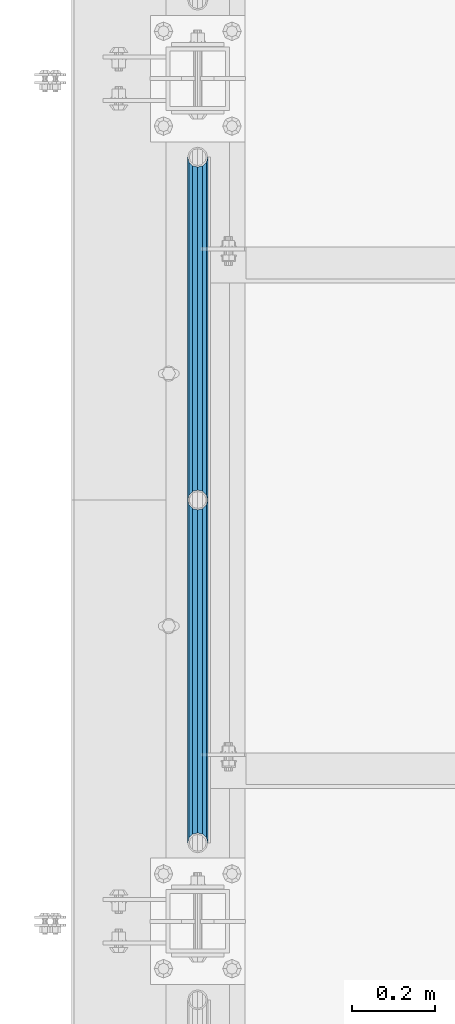
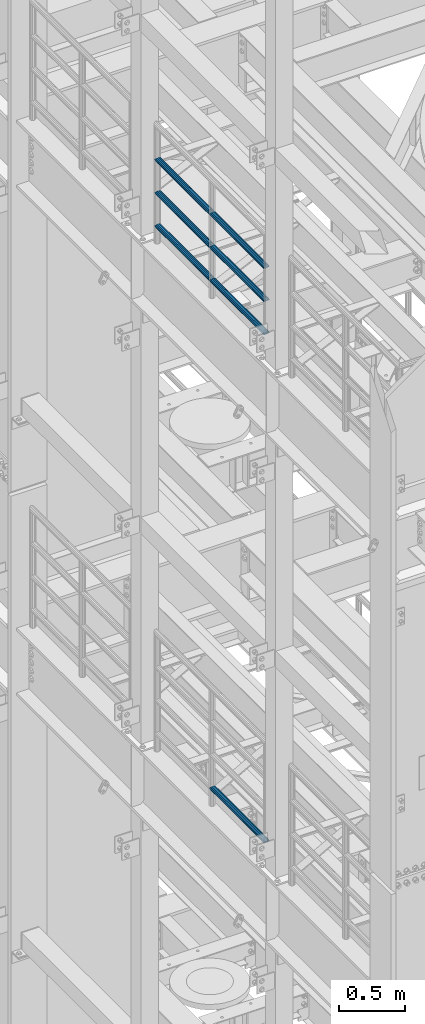
# One storey, part 1226 of 1876: 7 beams, 2 elements without a shape of their own.
"""IFC2X3 building model written with IfcOpenShell, lengths in millimetres."""

from ifc_helpers import new_model, si_unit, frame, origin_with_axes, place, context, subcontext, project, spatial, faceted_brep, material, type_object, element, aggregate, save


model = new_model("IFC2X3")

# Units and contexts
model_context = context("Model", 3, precision=1e-05, world=origin_with_axes())
body_context = subcontext(model_context, "Body", "Model", "MODEL_VIEW")
ifc_project = project(units=[si_unit("LENGTHUNIT", "METRE", prefix="MILLI"), si_unit("AREAUNIT", "SQUARE_METRE"), si_unit("VOLUMEUNIT", "CUBIC_METRE"), si_unit("MASSUNIT", "GRAM", prefix="KILO"), si_unit("TIMEUNIT", "SECOND"), si_unit("PLANEANGLEUNIT", "RADIAN"), si_unit("SOLIDANGLEUNIT", "STERADIAN"), si_unit("THERMODYNAMICTEMPERATUREUNIT", "DEGREE_CELSIUS"), si_unit("LUMINOUSINTENSITYUNIT", "LUMEN")], contexts=[model_context])

# Site, building, storey
site_placement = place(None, origin_with_axes())
site = spatial("IfcSite", under=ifc_project, at=site_placement, CompositionType="ELEMENT")
building_placement = place(site_placement, origin_with_axes())
building = spatial("IfcBuilding", under=site, at=building_placement, Name="Undefined", CompositionType="ELEMENT")
storey_placement = place(building_placement, origin_with_axes())
storey = spatial("IfcBuildingStorey", under=building, at=storey_placement, Name="Undefined", CompositionType="ELEMENT", Elevation=0.0)

# Assembly, beams
assembly_1_placement = place(storey_placement, origin_with_axes())
assembly_1 = element("IfcElementAssembly", 1, at=assembly_1_placement, inside=storey, Name="RAIL", AssemblyPlace="NOTDEFINED", PredefinedType="RIGID_FRAME")
ifc_material = material()
beam_type = type_object("IfcBeamType", Name="PIPE1-1/2SCH40", PredefinedType="NOTDEFINED")
beam_1_placement = place(assembly_1_placement, frame((-1.81898940354586e-12, -1524.0, 18145.125), z_axis=(0.0, 0.0, 1.0), x_axis=(0.0, -1.0, 0.0)))
beam_1 = element("IfcBeam", 2, at=beam_1_placement, type_object=beam_type, material=ifc_material, Name="RAIL", ObjectType="PIPE1-1/2SCH40", context=body_context, shape_type="Brep", body=[
    faceted_brep([(805.872807006681, -12.0649999999996, 20.8971929933177), (805.872807006683, -12.0649999999996, 15.8661214311796), (805.379378568819, -10.2235000000001, 17.7076214311819), (802.640000000001, 0.0, 20.4470000000001), (802.640000000001, 0.0, 24.130000000001), (805.379378568819, 10.2235000000001, 17.7076214311819), (805.872807006683, 12.0649999999996, 15.8661214311796), (805.872807006681, 12.0649999999996, 20.8971929933177), (826.77, 24.1300000000001, 0.0), (814.705, 20.8971929933186, 12.0649999999987), (814.705, 20.8971929933186, -12.0649999999987), (811.515428437862, 17.7076214311801, 10.2235000000001), (814.254807006682, 20.4470000000001, 0.0), (811.515428437862, 17.7076214311801, -10.2235000000001), (805.872807006683, 12.0649999999996, -15.8661214311796), (805.872807006681, 12.0649999999996, -20.8971929933177), (805.379378568819, 10.2235000000001, -17.7076214311819), (802.640000000001, 0.0, -20.4470000000001), (802.640000000001, 0.0, -24.130000000001), (805.872807006683, -12.0649999999996, -15.8661214311796), (805.872807006681, -12.0649999999996, -20.8971929933177), (805.379378568819, -10.2235000000001, -17.7076214311819), (826.77, -24.1300000000001, 0.0), (814.705, -20.8971929933186, -12.0649999999987), (814.705, -20.8971929933186, 12.0649999999987), (811.515428437862, -17.7076214311801, -10.2235000000001), (814.254807006682, -20.4470000000001, 0.0), (811.515428437862, -17.7076214311801, 10.2235000000001), (12.0650000000064, -20.8971929933177, -12.0649999999987), (20.8971929933249, -12.0650000000005, -20.8971929933177), (0.0, 24.1299999999992, 0.0), (12.0650000000064, 20.8971929933177, -12.0649999999987), (12.0650000000064, 20.8971929933177, 12.0649999999987), (20.8971929933249, 12.0650000000005, 20.8971929933177), (24.1300000000064, 0.0, 24.130000000001), (20.8971929933249, 12.0650000000005, -20.8971929933177), (24.1300000000063, 0.0, -24.130000000001), (24.1300000000063, 0.0, -20.4470000000001), (20.8971929933249, -12.0650000000005, -15.8661214311796), (21.3906214311868, -10.2235000000001, -17.7076214311819), (21.3906214311868, 10.2235000000001, -17.7076214311819), (20.8971929933249, 12.0650000000005, -15.8661214311796), (15.2545715621445, 17.7076214311801, -10.2235000000001), (12.5151929933249, 20.4470000000001, 0.0), (15.2545715621445, 17.7076214311801, 10.2235000000001), (20.8971929933249, 12.0650000000005, 15.8661214311796), (21.3906214311868, 10.2235000000001, 17.7076214311819), (24.1300000000064, 0.0, 20.4470000000001), (21.3906214311868, -10.2235000000001, 17.7076214311819), (20.8971929933249, -12.0650000000005, 15.8661214311796), (20.8971929933249, -12.0650000000005, 20.8971929933177), (12.0650000000064, -20.8971929933177, 12.0649999999987), (0.0, -24.1299999999992, 0.0), (15.2545715621445, -17.7076214311801, 10.2235000000001), (12.5151929933249, -20.4470000000001, 0.0), (15.2545715621445, -17.7076214311801, -10.2235000000001)], [[[0, 1, 2, 3, 4]], [[4, 3, 5, 6, 7]], [[8, 9, 10]], [[7, 6, 11, 12, 13, 14, 15, 10, 9]], [[16, 17, 18, 15, 14]], [[19, 20, 18, 17, 21]], [[22, 23, 24]], [[24, 23, 20, 19, 25, 26, 27, 1, 0]], [[28, 29, 20, 23]], [[30, 31, 32]], [[33, 34, 4, 7]], [[32, 33, 7, 9]], [[30, 32, 9, 8]], [[31, 30, 8, 10]], [[35, 31, 10, 15]], [[36, 35, 15, 18]], [[29, 36, 18, 20]], [[37, 36, 29, 38, 39]], [[40, 41, 35, 36, 37]], [[32, 31, 35, 41, 42, 43, 44, 45, 33]], [[33, 45, 46, 47, 34]], [[34, 47, 48, 49, 50]], [[34, 50, 0, 4]], [[50, 51, 24, 0]], [[51, 52, 22, 24]], [[52, 28, 23, 22]], [[51, 28, 52]], [[50, 49, 53, 54, 55, 38, 29, 28, 51]], [[55, 54, 26, 25]], [[21, 39, 38, 55, 25, 19]], [[37, 39, 21, 17]], [[40, 37, 17, 16]], [[42, 41, 40, 16, 14, 13]], [[43, 42, 13, 12]], [[44, 43, 12, 11]], [[5, 46, 45, 44, 11, 6]], [[47, 46, 5, 3]], [[48, 47, 3, 2]], [[53, 49, 48, 2, 1, 27]], [[54, 53, 27, 26]]]),
])
beam_2_placement = place(assembly_1_placement, frame((-1.81898940354586e-12, -697.230000000001, 18145.125), z_axis=(0.0, 0.0, 1.0), x_axis=(0.0, -1.0, 0.0)))
beam_2 = element("IfcBeam", 3, at=beam_2_placement, type_object=beam_type, material=ifc_material, Name="RAIL", ObjectType="PIPE1-1/2SCH40", context=body_context, shape_type="Brep", body=[
    faceted_brep([(805.872807006681, -12.0649999999996, 20.8971929933177), (805.872807006683, -12.0649999999996, 15.8661214311796), (805.379378568819, -10.2235000000001, 17.7076214311819), (802.640000000001, 0.0, 20.4470000000001), (802.640000000001, 0.0, 24.130000000001), (805.379378568819, 10.2235000000001, 17.7076214311819), (805.872807006683, 12.0649999999996, 15.8661214311796), (805.872807006681, 12.0649999999996, 20.8971929933177), (826.77, 24.1300000000001, 0.0), (814.705, 20.8971929933186, 12.0649999999987), (814.705, 20.8971929933186, -12.0649999999987), (811.515428437862, 17.7076214311801, 10.2235000000001), (814.254807006682, 20.4470000000001, 0.0), (811.515428437862, 17.7076214311801, -10.2235000000001), (805.872807006683, 12.0649999999996, -15.8661214311796), (805.872807006681, 12.0649999999996, -20.8971929933177), (805.379378568819, 10.2235000000001, -17.7076214311819), (802.640000000001, 0.0, -20.4470000000001), (802.640000000001, 0.0, -24.130000000001), (805.872807006683, -12.0649999999996, -15.8661214311796), (805.872807006681, -12.0649999999996, -20.8971929933177), (805.379378568819, -10.2235000000001, -17.7076214311819), (826.77, -24.1300000000001, 0.0), (814.705, -20.8971929933186, -12.0649999999987), (814.705, -20.8971929933186, 12.0649999999987), (811.515428437862, -17.7076214311801, -10.2235000000001), (814.254807006682, -20.4470000000001, 0.0), (811.515428437862, -17.7076214311801, 10.2235000000001), (12.0650000000064, -20.8971929933177, -12.0649999999987), (20.8971929933249, -12.0650000000005, -20.8971929933177), (0.0, 24.1299999999992, 0.0), (12.0650000000064, 20.8971929933177, -12.0649999999987), (12.0650000000064, 20.8971929933177, 12.0649999999987), (20.8971929933249, 12.0650000000005, 20.8971929933177), (24.1300000000064, 0.0, 24.130000000001), (20.8971929933249, 12.0650000000005, -20.8971929933177), (24.1300000000063, 0.0, -24.130000000001), (24.1300000000063, 0.0, -20.4470000000001), (20.8971929933249, -12.0650000000005, -15.8661214311796), (21.3906214311868, -10.2235000000001, -17.7076214311819), (21.3906214311868, 10.2235000000001, -17.7076214311819), (20.8971929933249, 12.0650000000005, -15.8661214311796), (15.2545715621445, 17.7076214311801, -10.2235000000001), (12.5151929933249, 20.4470000000001, 0.0), (15.2545715621445, 17.7076214311801, 10.2235000000001), (20.8971929933249, 12.0650000000005, 15.8661214311796), (21.3906214311868, 10.2235000000001, 17.7076214311819), (24.1300000000064, 0.0, 20.4470000000001), (21.3906214311868, -10.2235000000001, 17.7076214311819), (20.8971929933249, -12.0650000000005, 15.8661214311796), (20.8971929933249, -12.0650000000005, 20.8971929933177), (12.0650000000064, -20.8971929933177, 12.0649999999987), (0.0, -24.1299999999992, 0.0), (15.2545715621445, -17.7076214311801, 10.2235000000001), (12.5151929933249, -20.4470000000001, 0.0), (15.2545715621445, -17.7076214311801, -10.2235000000001)], [[[0, 1, 2, 3, 4]], [[4, 3, 5, 6, 7]], [[8, 9, 10]], [[7, 6, 11, 12, 13, 14, 15, 10, 9]], [[16, 17, 18, 15, 14]], [[19, 20, 18, 17, 21]], [[22, 23, 24]], [[24, 23, 20, 19, 25, 26, 27, 1, 0]], [[28, 29, 20, 23]], [[30, 31, 32]], [[33, 34, 4, 7]], [[32, 33, 7, 9]], [[30, 32, 9, 8]], [[31, 30, 8, 10]], [[35, 31, 10, 15]], [[36, 35, 15, 18]], [[29, 36, 18, 20]], [[37, 36, 29, 38, 39]], [[40, 41, 35, 36, 37]], [[32, 31, 35, 41, 42, 43, 44, 45, 33]], [[33, 45, 46, 47, 34]], [[34, 47, 48, 49, 50]], [[34, 50, 0, 4]], [[50, 51, 24, 0]], [[51, 52, 22, 24]], [[52, 28, 23, 22]], [[51, 28, 52]], [[50, 49, 53, 54, 55, 38, 29, 28, 51]], [[55, 54, 26, 25]], [[21, 39, 38, 55, 25, 19]], [[37, 39, 21, 17]], [[40, 37, 17, 16]], [[42, 41, 40, 16, 14, 13]], [[43, 42, 13, 12]], [[44, 43, 12, 11]], [[5, 46, 45, 44, 11, 6]], [[47, 46, 5, 3]], [[48, 47, 3, 2]], [[53, 49, 48, 2, 1, 27]], [[54, 53, 27, 26]]]),
])
beam_3_placement = place(assembly_1_placement, frame((-1.81898940354586e-12, -2350.77, 18449.925), z_axis=(0.0, 0.0, -1.0), x_axis=(0.0, 1.0, 0.0)))
beam_3 = element("IfcBeam", 4, at=beam_3_placement, type_object=beam_type, material=ifc_material, Name="RAIL", ObjectType="PIPE1-1/2SCH40", context=body_context, shape_type="Brep", body=[
    faceted_brep([(0.0, 24.1299999999992, 0.0), (12.0650000000064, 20.8971929933177, -12.0649999999987), (12.0650000000064, 20.8971929933177, 12.0649999999987), (12.0650000000064, -20.8971929933177, 12.0649999999987), (12.0650000000064, -20.8971929933177, -12.0649999999987), (0.0, -24.1299999999992, 0.0), (20.8971929933249, -12.0650000000005, 20.8971929933177), (20.8971929933249, -12.0650000000005, 15.8661214311796), (15.2545715621445, -17.7076214311801, 10.2235000000001), (12.5151929933249, -20.4470000000001, 0.0), (15.2545715621445, -17.7076214311801, -10.2235000000001), (20.8971929933249, -12.0650000000005, -15.8661214311796), (20.8971929933249, -12.0650000000005, -20.8971929933177), (24.1300000000063, 0.0, -20.4470000000001), (24.1300000000063, 0.0, -24.130000000001), (21.3906214311868, -10.2235000000001, -17.7076214311819), (21.3906214311868, 10.2235000000001, -17.7076214311819), (20.8971929933249, 12.0650000000005, -15.8661214311796), (20.8971929933249, 12.0650000000005, -20.8971929933177), (15.2545715621445, 17.7076214311801, -10.2235000000001), (12.5151929933249, 20.4470000000001, 0.0), (15.2545715621445, 17.7076214311801, 10.2235000000001), (20.8971929933249, 12.0650000000005, 15.8661214311796), (20.8971929933249, 12.0650000000005, 20.8971929933177), (21.3906214311868, 10.2235000000001, 17.7076214311819), (24.1300000000064, 0.0, 20.4470000000001), (24.1300000000064, 0.0, 24.130000000001), (21.3906214311868, -10.2235000000001, 17.7076214311819), (826.77, 24.1300000000001, 0.0), (814.705, 20.8971929933186, -12.0649999999987), (805.872807006681, 12.0649999999996, -20.8971929933177), (826.77, -24.1300000000001, 0.0), (814.705, -20.8971929933186, -12.0649999999987), (814.705, -20.8971929933186, 12.0649999999987), (805.872807006681, -12.0649999999996, 20.8971929933177), (805.872807006681, -12.0649999999996, -20.8971929933177), (802.640000000001, 0.0, -24.130000000001), (805.379378568819, 10.2235000000001, -17.7076214311819), (802.640000000001, 0.0, -20.4470000000001), (805.872807006683, 12.0649999999996, -15.8661214311796), (805.872807006683, -12.0649999999996, -15.8661214311796), (805.379378568819, -10.2235000000001, -17.7076214311819), (811.515428437862, -17.7076214311801, -10.2235000000001), (814.254807006682, -20.4470000000001, 0.0), (811.515428437862, -17.7076214311801, 10.2235000000001), (805.872807006683, -12.0649999999996, 15.8661214311796), (805.379378568819, -10.2235000000001, 17.7076214311819), (802.640000000001, 0.0, 20.4470000000001), (802.640000000001, 0.0, 24.130000000001), (805.872807006681, 12.0649999999996, 20.8971929933177), (814.705, 20.8971929933186, 12.0649999999987), (805.872807006683, 12.0649999999996, 15.8661214311796), (811.515428437862, 17.7076214311801, 10.2235000000001), (814.254807006682, 20.4470000000001, 0.0), (811.515428437862, 17.7076214311801, -10.2235000000001), (805.379378568819, 10.2235000000001, 17.7076214311819)], [[[0, 1, 2]], [[3, 4, 5]], [[6, 7, 8, 9, 10, 11, 12, 4, 3]], [[13, 14, 12, 11, 15]], [[16, 17, 18, 14, 13]], [[2, 1, 18, 17, 19, 20, 21, 22, 23]], [[23, 22, 24, 25, 26]], [[26, 25, 27, 7, 6]], [[1, 0, 28, 29]], [[18, 1, 29, 30]], [[31, 32, 33]], [[6, 3, 33, 34]], [[3, 5, 31, 33]], [[5, 4, 32, 31]], [[4, 12, 35, 32]], [[12, 14, 36, 35]], [[14, 18, 30, 36]], [[37, 38, 36, 30, 39]], [[40, 35, 36, 38, 41]], [[33, 32, 35, 40, 42, 43, 44, 45, 34]], [[34, 45, 46, 47, 48]], [[26, 6, 34, 48]], [[2, 23, 49, 50]], [[23, 26, 48, 49]], [[0, 2, 50, 28]], [[28, 50, 29]], [[49, 51, 52, 53, 54, 39, 30, 29, 50]], [[48, 47, 55, 51, 49]], [[25, 24, 55, 47]], [[55, 24, 22, 21, 52, 51]], [[21, 20, 53, 52]], [[20, 19, 54, 53]], [[19, 17, 16, 37, 39, 54]], [[16, 13, 38, 37]], [[13, 15, 41, 38]], [[41, 15, 11, 10, 42, 40]], [[10, 9, 43, 42]], [[9, 8, 44, 43]], [[8, 7, 27, 46, 45, 44]], [[27, 25, 47, 46]]]),
])
beam_4_placement = place(assembly_1_placement, frame((-1.81898940354586e-12, -1524.0, 18449.925), z_axis=(0.0, 0.0, -1.0), x_axis=(0.0, 1.0, 0.0)))
beam_4 = element("IfcBeam", 5, at=beam_4_placement, type_object=beam_type, material=ifc_material, Name="RAIL", ObjectType="PIPE1-1/2SCH40", context=body_context, shape_type="Brep", body=[
    faceted_brep([(0.0, 24.1299999999992, 0.0), (12.0650000000064, 20.8971929933177, -12.0649999999987), (12.0650000000064, 20.8971929933177, 12.0649999999987), (12.0650000000064, -20.8971929933177, 12.0649999999987), (12.0650000000064, -20.8971929933177, -12.0649999999987), (0.0, -24.1299999999992, 0.0), (20.8971929933249, -12.0650000000005, 20.8971929933177), (20.8971929933249, -12.0650000000005, 15.8661214311796), (15.2545715621445, -17.7076214311801, 10.2235000000001), (12.5151929933249, -20.4470000000001, 0.0), (15.2545715621445, -17.7076214311801, -10.2235000000001), (20.8971929933249, -12.0650000000005, -15.8661214311796), (20.8971929933249, -12.0650000000005, -20.8971929933177), (24.1300000000063, 0.0, -20.4470000000001), (24.1300000000063, 0.0, -24.130000000001), (21.3906214311868, -10.2235000000001, -17.7076214311819), (21.3906214311868, 10.2235000000001, -17.7076214311819), (20.8971929933249, 12.0650000000005, -15.8661214311796), (20.8971929933249, 12.0650000000005, -20.8971929933177), (15.2545715621445, 17.7076214311801, -10.2235000000001), (12.5151929933249, 20.4470000000001, 0.0), (15.2545715621445, 17.7076214311801, 10.2235000000001), (20.8971929933249, 12.0650000000005, 15.8661214311796), (20.8971929933249, 12.0650000000005, 20.8971929933177), (21.3906214311868, 10.2235000000001, 17.7076214311819), (24.1300000000064, 0.0, 20.4470000000001), (24.1300000000064, 0.0, 24.130000000001), (21.3906214311868, -10.2235000000001, 17.7076214311819), (826.77, 24.1300000000001, 0.0), (814.705, 20.8971929933186, -12.0649999999987), (805.872807006681, 12.0649999999996, -20.8971929933177), (826.77, -24.1300000000001, 0.0), (814.705, -20.8971929933186, -12.0649999999987), (814.705, -20.8971929933186, 12.0649999999987), (805.872807006681, -12.0649999999996, 20.8971929933177), (805.872807006681, -12.0649999999996, -20.8971929933177), (802.640000000001, 0.0, -24.130000000001), (805.379378568819, 10.2235000000001, -17.7076214311819), (802.640000000001, 0.0, -20.4470000000001), (805.872807006683, 12.0649999999996, -15.8661214311796), (805.872807006683, -12.0649999999996, -15.8661214311796), (805.379378568819, -10.2235000000001, -17.7076214311819), (811.515428437862, -17.7076214311801, -10.2235000000001), (814.254807006682, -20.4470000000001, 0.0), (811.515428437862, -17.7076214311801, 10.2235000000001), (805.872807006683, -12.0649999999996, 15.8661214311796), (805.379378568819, -10.2235000000001, 17.7076214311819), (802.640000000001, 0.0, 20.4470000000001), (802.640000000001, 0.0, 24.130000000001), (805.872807006681, 12.0649999999996, 20.8971929933177), (814.705, 20.8971929933186, 12.0649999999987), (805.872807006683, 12.0649999999996, 15.8661214311796), (811.515428437862, 17.7076214311801, 10.2235000000001), (814.254807006682, 20.4470000000001, 0.0), (811.515428437862, 17.7076214311801, -10.2235000000001), (805.379378568819, 10.2235000000001, 17.7076214311819)], [[[0, 1, 2]], [[3, 4, 5]], [[6, 7, 8, 9, 10, 11, 12, 4, 3]], [[13, 14, 12, 11, 15]], [[16, 17, 18, 14, 13]], [[2, 1, 18, 17, 19, 20, 21, 22, 23]], [[23, 22, 24, 25, 26]], [[26, 25, 27, 7, 6]], [[1, 0, 28, 29]], [[18, 1, 29, 30]], [[31, 32, 33]], [[6, 3, 33, 34]], [[3, 5, 31, 33]], [[5, 4, 32, 31]], [[4, 12, 35, 32]], [[12, 14, 36, 35]], [[14, 18, 30, 36]], [[37, 38, 36, 30, 39]], [[40, 35, 36, 38, 41]], [[33, 32, 35, 40, 42, 43, 44, 45, 34]], [[34, 45, 46, 47, 48]], [[26, 6, 34, 48]], [[2, 23, 49, 50]], [[23, 26, 48, 49]], [[0, 2, 50, 28]], [[28, 50, 29]], [[49, 51, 52, 53, 54, 39, 30, 29, 50]], [[48, 47, 55, 51, 49]], [[25, 24, 55, 47]], [[55, 24, 22, 21, 52, 51]], [[21, 20, 53, 52]], [[20, 19, 54, 53]], [[19, 17, 16, 37, 39, 54]], [[16, 13, 38, 37]], [[13, 15, 41, 38]], [[41, 15, 11, 10, 42, 40]], [[10, 9, 43, 42]], [[9, 8, 44, 43]], [[8, 7, 27, 46, 45, 44]], [[27, 25, 47, 46]]]),
])
beam_5_placement = place(assembly_1_placement, frame((-1.81898940354586e-12, -2350.77, 18754.725), z_axis=(0.0, 0.0, -1.0), x_axis=(0.0, 1.0, 0.0)))
beam_5 = element("IfcBeam", 6, at=beam_5_placement, type_object=beam_type, material=ifc_material, Name="RAIL", ObjectType="PIPE1-1/2SCH40", context=body_context, shape_type="Brep", body=[
    faceted_brep([(0.0, 24.1299999999992, 0.0), (12.0650000000064, 20.8971929933177, -12.0649999999987), (12.0650000000064, 20.8971929933177, 12.0649999999987), (12.0650000000064, -20.8971929933177, 12.0649999999987), (12.0650000000064, -20.8971929933177, -12.0649999999987), (0.0, -24.1299999999992, 0.0), (20.8971929933249, -12.0650000000005, 20.8971929933177), (20.8971929933249, -12.0650000000005, 15.8661214311796), (15.2545715621445, -17.7076214311801, 10.2235000000001), (12.5151929933249, -20.4470000000001, 0.0), (15.2545715621445, -17.7076214311801, -10.2235000000001), (20.8971929933249, -12.0650000000005, -15.8661214311796), (20.8971929933249, -12.0650000000005, -20.8971929933177), (24.1300000000063, 0.0, -20.4470000000001), (24.1300000000063, 0.0, -24.130000000001), (21.3906214311868, -10.2235000000001, -17.7076214311819), (21.3906214311868, 10.2235000000001, -17.7076214311819), (20.8971929933249, 12.0650000000005, -15.8661214311796), (20.8971929933249, 12.0650000000005, -20.8971929933177), (15.2545715621445, 17.7076214311801, -10.2235000000001), (12.5151929933249, 20.4470000000001, 0.0), (15.2545715621445, 17.7076214311801, 10.2235000000001), (20.8971929933249, 12.0650000000005, 15.8661214311796), (20.8971929933249, 12.0650000000005, 20.8971929933177), (21.3906214311868, 10.2235000000001, 17.7076214311819), (24.1300000000064, 0.0, 20.4470000000001), (24.1300000000064, 0.0, 24.130000000001), (21.3906214311868, -10.2235000000001, 17.7076214311819), (826.77, 24.1300000000001, 0.0), (814.705, 20.8971929933186, -12.0649999999987), (805.872807006681, 12.0649999999996, -20.8971929933177), (826.77, -24.1300000000001, 0.0), (814.705, -20.8971929933186, -12.0649999999987), (814.705, -20.8971929933186, 12.0649999999987), (805.872807006681, -12.0649999999996, 20.8971929933177), (805.872807006681, -12.0649999999996, -20.8971929933177), (802.640000000001, 0.0, -24.130000000001), (805.379378568819, 10.2235000000001, -17.7076214311819), (802.640000000001, 0.0, -20.4470000000001), (805.872807006683, 12.0649999999996, -15.8661214311796), (805.872807006683, -12.0649999999996, -15.8661214311796), (805.379378568819, -10.2235000000001, -17.7076214311819), (811.515428437862, -17.7076214311801, -10.2235000000001), (814.254807006682, -20.4470000000001, 0.0), (811.515428437862, -17.7076214311801, 10.2235000000001), (805.872807006683, -12.0649999999996, 15.8661214311796), (805.379378568819, -10.2235000000001, 17.7076214311819), (802.640000000001, 0.0, 20.4470000000001), (802.640000000001, 0.0, 24.130000000001), (805.872807006681, 12.0649999999996, 20.8971929933177), (814.705, 20.8971929933186, 12.0649999999987), (805.872807006683, 12.0649999999996, 15.8661214311796), (811.515428437862, 17.7076214311801, 10.2235000000001), (814.254807006682, 20.4470000000001, 0.0), (811.515428437862, 17.7076214311801, -10.2235000000001), (805.379378568819, 10.2235000000001, 17.7076214311819)], [[[0, 1, 2]], [[3, 4, 5]], [[6, 7, 8, 9, 10, 11, 12, 4, 3]], [[13, 14, 12, 11, 15]], [[16, 17, 18, 14, 13]], [[2, 1, 18, 17, 19, 20, 21, 22, 23]], [[23, 22, 24, 25, 26]], [[26, 25, 27, 7, 6]], [[1, 0, 28, 29]], [[18, 1, 29, 30]], [[31, 32, 33]], [[6, 3, 33, 34]], [[3, 5, 31, 33]], [[5, 4, 32, 31]], [[4, 12, 35, 32]], [[12, 14, 36, 35]], [[14, 18, 30, 36]], [[37, 38, 36, 30, 39]], [[40, 35, 36, 38, 41]], [[33, 32, 35, 40, 42, 43, 44, 45, 34]], [[34, 45, 46, 47, 48]], [[26, 6, 34, 48]], [[2, 23, 49, 50]], [[23, 26, 48, 49]], [[0, 2, 50, 28]], [[28, 50, 29]], [[49, 51, 52, 53, 54, 39, 30, 29, 50]], [[48, 47, 55, 51, 49]], [[25, 24, 55, 47]], [[55, 24, 22, 21, 52, 51]], [[21, 20, 53, 52]], [[20, 19, 54, 53]], [[19, 17, 16, 37, 39, 54]], [[16, 13, 38, 37]], [[13, 15, 41, 38]], [[41, 15, 11, 10, 42, 40]], [[10, 9, 43, 42]], [[9, 8, 44, 43]], [[8, 7, 27, 46, 45, 44]], [[27, 25, 47, 46]]]),
])
beam_6_placement = place(assembly_1_placement, frame((-1.81898940354586e-12, -1524.0, 18754.725), z_axis=(0.0, 0.0, -1.0), x_axis=(0.0, 1.0, 0.0)))
beam_6 = element("IfcBeam", 7, at=beam_6_placement, type_object=beam_type, material=ifc_material, Name="RAIL", ObjectType="PIPE1-1/2SCH40", context=body_context, shape_type="Brep", body=[
    faceted_brep([(0.0, 24.1299999999992, 0.0), (12.0650000000064, 20.8971929933177, -12.0649999999987), (12.0650000000064, 20.8971929933177, 12.0649999999987), (12.0650000000064, -20.8971929933177, 12.0649999999987), (12.0650000000064, -20.8971929933177, -12.0649999999987), (0.0, -24.1299999999992, 0.0), (20.8971929933249, -12.0650000000005, 20.8971929933177), (20.8971929933249, -12.0650000000005, 15.8661214311796), (15.2545715621445, -17.7076214311801, 10.2235000000001), (12.5151929933249, -20.4470000000001, 0.0), (15.2545715621445, -17.7076214311801, -10.2235000000001), (20.8971929933249, -12.0650000000005, -15.8661214311796), (20.8971929933249, -12.0650000000005, -20.8971929933177), (24.1300000000063, 0.0, -20.4470000000001), (24.1300000000063, 0.0, -24.130000000001), (21.3906214311868, -10.2235000000001, -17.7076214311819), (21.3906214311868, 10.2235000000001, -17.7076214311819), (20.8971929933249, 12.0650000000005, -15.8661214311796), (20.8971929933249, 12.0650000000005, -20.8971929933177), (15.2545715621445, 17.7076214311801, -10.2235000000001), (12.5151929933249, 20.4470000000001, 0.0), (15.2545715621445, 17.7076214311801, 10.2235000000001), (20.8971929933249, 12.0650000000005, 15.8661214311796), (20.8971929933249, 12.0650000000005, 20.8971929933177), (21.3906214311868, 10.2235000000001, 17.7076214311819), (24.1300000000064, 0.0, 20.4470000000001), (24.1300000000064, 0.0, 24.130000000001), (21.3906214311868, -10.2235000000001, 17.7076214311819), (826.77, 24.1300000000001, 0.0), (814.705, 20.8971929933186, -12.0649999999987), (805.872807006681, 12.0649999999996, -20.8971929933177), (826.77, -24.1300000000001, 0.0), (814.705, -20.8971929933186, -12.0649999999987), (814.705, -20.8971929933186, 12.0649999999987), (805.872807006681, -12.0649999999996, 20.8971929933177), (805.872807006681, -12.0649999999996, -20.8971929933177), (802.640000000001, 0.0, -24.130000000001), (805.379378568819, 10.2235000000001, -17.7076214311819), (802.640000000001, 0.0, -20.4470000000001), (805.872807006683, 12.0649999999996, -15.8661214311796), (805.872807006683, -12.0649999999996, -15.8661214311796), (805.379378568819, -10.2235000000001, -17.7076214311819), (811.515428437862, -17.7076214311801, -10.2235000000001), (814.254807006682, -20.4470000000001, 0.0), (811.515428437862, -17.7076214311801, 10.2235000000001), (805.872807006683, -12.0649999999996, 15.8661214311796), (805.379378568819, -10.2235000000001, 17.7076214311819), (802.640000000001, 0.0, 20.4470000000001), (802.640000000001, 0.0, 24.130000000001), (805.872807006681, 12.0649999999996, 20.8971929933177), (814.705, 20.8971929933186, 12.0649999999987), (805.872807006683, 12.0649999999996, 15.8661214311796), (811.515428437862, 17.7076214311801, 10.2235000000001), (814.254807006682, 20.4470000000001, 0.0), (811.515428437862, 17.7076214311801, -10.2235000000001), (805.379378568819, 10.2235000000001, 17.7076214311819)], [[[0, 1, 2]], [[3, 4, 5]], [[6, 7, 8, 9, 10, 11, 12, 4, 3]], [[13, 14, 12, 11, 15]], [[16, 17, 18, 14, 13]], [[2, 1, 18, 17, 19, 20, 21, 22, 23]], [[23, 22, 24, 25, 26]], [[26, 25, 27, 7, 6]], [[1, 0, 28, 29]], [[18, 1, 29, 30]], [[31, 32, 33]], [[6, 3, 33, 34]], [[3, 5, 31, 33]], [[5, 4, 32, 31]], [[4, 12, 35, 32]], [[12, 14, 36, 35]], [[14, 18, 30, 36]], [[37, 38, 36, 30, 39]], [[40, 35, 36, 38, 41]], [[33, 32, 35, 40, 42, 43, 44, 45, 34]], [[34, 45, 46, 47, 48]], [[26, 6, 34, 48]], [[2, 23, 49, 50]], [[23, 26, 48, 49]], [[0, 2, 50, 28]], [[28, 50, 29]], [[49, 51, 52, 53, 54, 39, 30, 29, 50]], [[48, 47, 55, 51, 49]], [[25, 24, 55, 47]], [[55, 24, 22, 21, 52, 51]], [[21, 20, 53, 52]], [[20, 19, 54, 53]], [[19, 17, 16, 37, 39, 54]], [[16, 13, 38, 37]], [[13, 15, 41, 38]], [[41, 15, 11, 10, 42, 40]], [[10, 9, 43, 42]], [[9, 8, 44, 43]], [[8, 7, 27, 46, 45, 44]], [[27, 25, 47, 46]]]),
])
aggregate(assembly_1, [beam_1, beam_2, beam_3, beam_4, beam_5, beam_6])

# Assembly, beam
assembly_2_placement = place(storey_placement, origin_with_axes())
assembly_2 = element("IfcElementAssembly", 8, at=assembly_2_placement, inside=storey, Name="RAIL", AssemblyPlace="NOTDEFINED", PredefinedType="RIGID_FRAME")
beam_7_placement = place(assembly_2_placement, frame((-1.81898940354586e-12, -1524.0, 13471.525), z_axis=(0.0, 0.0, 1.0), x_axis=(0.0, -1.0, 0.0)))
beam_7 = element("IfcBeam", 9, at=beam_7_placement, type_object=beam_type, material=ifc_material, Name="RAIL", ObjectType="PIPE1-1/2SCH40", context=body_context, shape_type="Brep", body=[
    faceted_brep([(805.872807006681, -12.0649999999996, 20.8971929933177), (805.872807006683, -12.0649999999996, 15.8661214311796), (805.379378568819, -10.2235000000001, 17.7076214311819), (802.640000000001, 0.0, 20.4470000000001), (802.640000000001, 0.0, 24.130000000001), (805.379378568819, 10.2235000000001, 17.7076214311819), (805.872807006683, 12.0649999999996, 15.8661214311796), (805.872807006681, 12.0649999999996, 20.8971929933177), (826.77, 24.1300000000001, 0.0), (814.705, 20.8971929933186, 12.0649999999987), (814.705, 20.8971929933186, -12.0649999999987), (811.515428437862, 17.7076214311801, 10.2235000000001), (814.254807006682, 20.4470000000001, 0.0), (811.515428437862, 17.7076214311801, -10.2235000000001), (805.872807006683, 12.0649999999996, -15.8661214311796), (805.872807006681, 12.0649999999996, -20.8971929933177), (805.379378568819, 10.2235000000001, -17.7076214311819), (802.640000000001, 0.0, -20.4470000000001), (802.640000000001, 0.0, -24.130000000001), (805.872807006683, -12.0649999999996, -15.8661214311796), (805.872807006681, -12.0649999999996, -20.8971929933177), (805.379378568819, -10.2235000000001, -17.7076214311819), (826.77, -24.1300000000001, 0.0), (814.705, -20.8971929933186, -12.0649999999987), (814.705, -20.8971929933186, 12.0649999999987), (811.515428437862, -17.7076214311801, -10.2235000000001), (814.254807006682, -20.4470000000001, 0.0), (811.515428437862, -17.7076214311801, 10.2235000000001), (12.0650000000064, -20.8971929933177, -12.0649999999987), (20.8971929933249, -12.0650000000005, -20.8971929933177), (0.0, 24.1299999999992, 0.0), (12.0650000000064, 20.8971929933177, -12.0649999999987), (12.0650000000064, 20.8971929933177, 12.0649999999987), (20.8971929933249, 12.0650000000005, 20.8971929933177), (24.1300000000064, 0.0, 24.130000000001), (20.8971929933249, 12.0650000000005, -20.8971929933177), (24.1300000000063, 0.0, -24.130000000001), (24.1300000000063, 0.0, -20.4470000000001), (20.8971929933249, -12.0650000000005, -15.8661214311796), (21.3906214311868, -10.2235000000001, -17.7076214311819), (21.3906214311868, 10.2235000000001, -17.7076214311819), (20.8971929933249, 12.0650000000005, -15.8661214311796), (15.2545715621445, 17.7076214311801, -10.2235000000001), (12.5151929933249, 20.4470000000001, 0.0), (15.2545715621445, 17.7076214311801, 10.2235000000001), (20.8971929933249, 12.0650000000005, 15.8661214311796), (21.3906214311868, 10.2235000000001, 17.7076214311819), (24.1300000000064, 0.0, 20.4470000000001), (21.3906214311868, -10.2235000000001, 17.7076214311819), (20.8971929933249, -12.0650000000005, 15.8661214311796), (20.8971929933249, -12.0650000000005, 20.8971929933177), (12.0650000000064, -20.8971929933177, 12.0649999999987), (0.0, -24.1299999999992, 0.0), (15.2545715621445, -17.7076214311801, 10.2235000000001), (12.5151929933249, -20.4470000000001, 0.0), (15.2545715621445, -17.7076214311801, -10.2235000000001)], [[[0, 1, 2, 3, 4]], [[4, 3, 5, 6, 7]], [[8, 9, 10]], [[7, 6, 11, 12, 13, 14, 15, 10, 9]], [[16, 17, 18, 15, 14]], [[19, 20, 18, 17, 21]], [[22, 23, 24]], [[24, 23, 20, 19, 25, 26, 27, 1, 0]], [[28, 29, 20, 23]], [[30, 31, 32]], [[33, 34, 4, 7]], [[32, 33, 7, 9]], [[30, 32, 9, 8]], [[31, 30, 8, 10]], [[35, 31, 10, 15]], [[36, 35, 15, 18]], [[29, 36, 18, 20]], [[37, 36, 29, 38, 39]], [[40, 41, 35, 36, 37]], [[32, 31, 35, 41, 42, 43, 44, 45, 33]], [[33, 45, 46, 47, 34]], [[34, 47, 48, 49, 50]], [[34, 50, 0, 4]], [[50, 51, 24, 0]], [[51, 52, 22, 24]], [[52, 28, 23, 22]], [[51, 28, 52]], [[50, 49, 53, 54, 55, 38, 29, 28, 51]], [[55, 54, 26, 25]], [[21, 39, 38, 55, 25, 19]], [[37, 39, 21, 17]], [[40, 37, 17, 16]], [[42, 41, 40, 16, 14, 13]], [[43, 42, 13, 12]], [[44, 43, 12, 11]], [[5, 46, 45, 44, 11, 6]], [[47, 46, 5, 3]], [[48, 47, 3, 2]], [[53, 49, 48, 2, 1, 27]], [[54, 53, 27, 26]]]),
])
aggregate(assembly_2, [beam_7])

save(model, "model.ifc")
